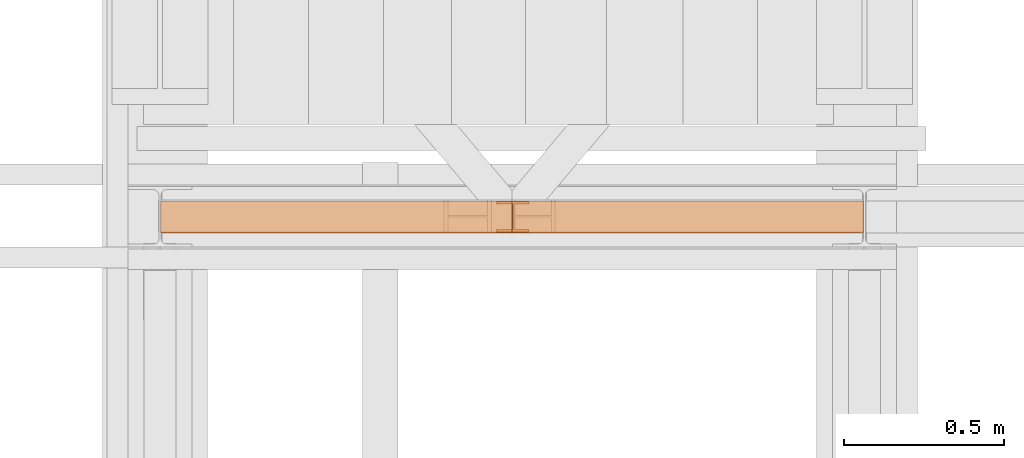
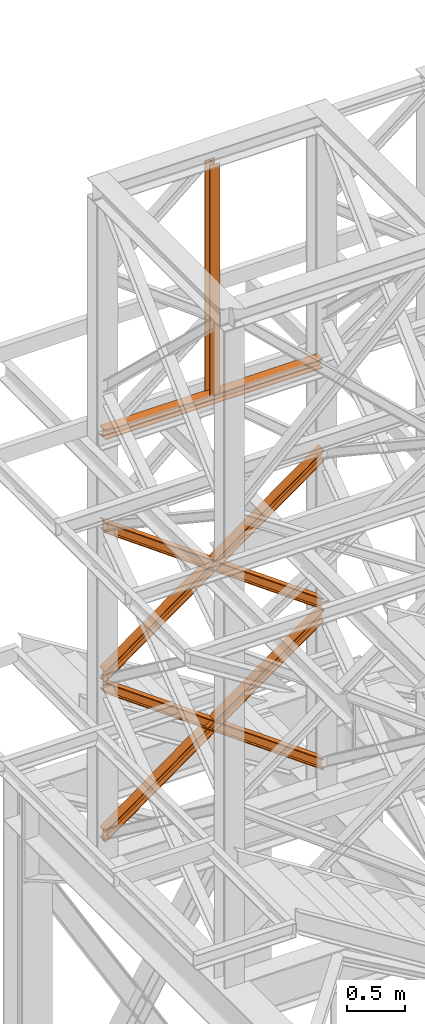
# One storey, part 102 of 208: 6 proxies.
"""IFC2X3 building model written with IfcOpenShell, lengths in millimetres."""

from ifc_helpers import new_model, entity, si_unit, converted_unit, frame, origin, origin_with_axes, place, context, subcontext, project, spatial, faceted_brep, element, save


model = new_model("IFC2X3")

# Units and contexts
model_context = context("Model", 3, precision=1e-05, world=origin())
plan_context = context("Plan", 3, precision=1e-05, world=origin())
body_context = subcontext(model_context, "Body", "Model", "MODEL_VIEW")
ifc_project = project(units=[si_unit("LENGTHUNIT", "METRE", prefix="MILLI"), converted_unit("PLANEANGLEUNIT", "DEGREE", entity("IfcPlaneAngleMeasure", 0.0174532925199433), si_unit("PLANEANGLEUNIT", "RADIAN"), dimensions=[0, 0, 0, 0, 0, 0, 0]), si_unit("AREAUNIT", "SQUARE_METRE"), si_unit("VOLUMEUNIT", "CUBIC_METRE")], contexts=[model_context, plan_context])

# Building, storey
building_placement = place(None, origin())
building = spatial("IfcBuilding", under=ifc_project, at=building_placement, CompositionType="COMPLEX")
storey_placement = place(building_placement, origin_with_axes())
storey = spatial("IfcBuildingStorey", under=building, at=storey_placement, Name="Geschoss", CompositionType="ELEMENT")

# Proxies
proxy_1_placement = place(storey_placement, frame((-3304.245031471322, -13812.57439031789, 5434.990005364416), z_axis=(0.0, 0.0, 1.0), x_axis=(1.0, 0.0, 0.0)))
element("IfcBuildingElementProxy", 1, at=proxy_1_placement, inside=storey, context=body_context, shape_type="Brep", body=[
    faceted_brep([(2194.25999993293, 0.01000000000021828, 1583.81921929576), (0.01000000000021828, 0.01000000000021828, 0.01000000000112777), (0.01000000000021828, 0.01000000000021828, 9.69256505868816), (2194.25999993293, 0.01000000000021828, 1593.501784354445), (2194.25999993293, 100.0100000000002, 1583.819219295759), (0.01000000000021828, 100.0100000000002, 0.01000000000021828), (0.01000000000021828, 0.01000000000021828, 0.01000000000112777), (2194.25999993293, 0.01000000000021828, 1583.81921929576), (2194.25999993293, 100.0100000000002, 1593.501784354445), (0.01000000000021828, 100.0100000000002, 9.69256505868816), (0.01000000000021828, 100.0100000000002, 0.01000000000021828), (2194.25999993293, 100.0100000000002, 1583.819219295759), (2194.25999993293, 52.51000000000022, 1593.501784354445), (0.01000000000021828, 52.51000000000022, 9.69256505868816), (0.01000000000021828, 100.0100000000002, 9.69256505868816), (2194.25999993293, 100.0100000000002, 1593.501784354445), (2194.259999932929, 52.51000000000022, 1690.327434941312), (0.01000000000021828, 52.51000000000022, 106.5182156455558), (0.01000000000021828, 52.51000000000022, 9.69256505868816), (2194.25999993293, 52.51000000000022, 1593.501784354445), (2194.25999993293, 100.0100000000002, 1690.327434941312), (0.01000000000203727, 100.0100000000002, 106.5182156455558), (0.01000000000021828, 52.51000000000022, 106.5182156455558), (2194.259999932929, 52.51000000000022, 1690.327434941312), (2194.25999993293, 100.0100000000002, 1700.01), (0.01000000000021828, 100.0100000000002, 116.2007807042428), (0.01000000000203727, 100.0100000000002, 106.5182156455558), (2194.25999993293, 100.0100000000002, 1690.327434941312), (2194.259999932929, 0.01000000000021828, 1700.01), (0.01000000000021828, 0.01000000000021828, 116.2007807042428), (0.01000000000021828, 100.0100000000002, 116.2007807042428), (2194.25999993293, 100.0100000000002, 1700.01), (2194.25999993293, 0.01000000000021828, 1690.327434941312), (0.01000000000021828, 0.01000000000021828, 106.5182156455549), (0.01000000000021828, 0.01000000000021828, 116.2007807042428), (2194.259999932929, 0.01000000000021828, 1700.01), (2194.25999993293, 47.51000000000022, 1690.327434941311), (0.01000000000021828, 47.51000000000022, 106.5182156455549), (0.01000000000021828, 0.01000000000021828, 106.5182156455549), (2194.25999993293, 0.01000000000021828, 1690.327434941312), (2194.25999993293, 47.51000000000022, 1593.501784354445), (0.01000000000021828, 47.51000000000022, 9.69256505868816), (0.01000000000021828, 47.51000000000022, 106.5182156455549), (2194.25999993293, 47.51000000000022, 1690.327434941311), (2194.25999993293, 0.01000000000021828, 1593.501784354445), (0.01000000000021828, 0.01000000000021828, 9.69256505868816), (0.01000000000021828, 47.51000000000022, 9.69256505868816), (2194.25999993293, 47.51000000000022, 1593.501784354445), (2194.25999993293, 0.01000000000021828, 1593.501784354445), (2194.25999993293, 47.51000000000022, 1593.501784354445), (2194.25999993293, 47.51000000000022, 1690.327434941311), (2194.25999993293, 0.01000000000021828, 1690.327434941312), (2194.259999932929, 0.01000000000021828, 1700.01), (2194.25999993293, 100.0100000000002, 1700.01), (2194.25999993293, 100.0100000000002, 1690.327434941312), (2194.259999932929, 52.51000000000022, 1690.327434941312), (2194.25999993293, 52.51000000000022, 1593.501784354445), (2194.25999993293, 100.0100000000002, 1593.501784354445), (2194.25999993293, 100.0100000000002, 1583.819219295759), (2194.25999993293, 0.01000000000021828, 1583.81921929576), (0.01000000000021828, 0.01000000000021828, 0.01000000000112777), (0.01000000000021828, 100.0100000000002, 0.01000000000021828), (0.01000000000021828, 100.0100000000002, 9.69256505868816), (0.01000000000021828, 52.51000000000022, 9.69256505868816), (0.01000000000021828, 52.51000000000022, 106.5182156455558), (0.01000000000203727, 100.0100000000002, 106.5182156455558), (0.01000000000021828, 100.0100000000002, 116.2007807042428), (0.01000000000021828, 0.01000000000021828, 116.2007807042428), (0.01000000000021828, 0.01000000000021828, 106.5182156455549), (0.01000000000021828, 47.51000000000022, 106.5182156455549), (0.01000000000021828, 47.51000000000022, 9.69256505868816), (0.01000000000021828, 0.01000000000021828, 9.69256505868816)], [[[0, 1, 2, 3]], [[4, 5, 6, 7]], [[8, 9, 10, 11]], [[12, 13, 14, 15]], [[16, 17, 18, 19]], [[20, 21, 22, 23]], [[24, 25, 26, 27]], [[28, 29, 30, 31]], [[32, 33, 34, 35]], [[36, 37, 38, 39]], [[40, 41, 42, 43]], [[44, 45, 46, 47]], [[48, 49, 50, 51, 52, 53, 54, 55, 56, 57, 58, 59]], [[60, 61, 62, 63, 64, 65, 66, 67, 68, 69, 70, 71]]], orient=[[False], [False], [False], [False], [False], [False], [False], [False], [False], [False], [False], [False], [False], [False]]),
])
proxy_2_placement = place(storey_placement, frame((-3304.245031471322, -13812.57439031789, 5434.990005364416), z_axis=(0.0, 0.0, 1.0), x_axis=(1.0, 0.0, 0.0)))
element("IfcBuildingElementProxy", 2, at=proxy_2_placement, inside=storey, context=body_context, shape_type="Brep", body=[
    faceted_brep([(0.01000000000021828, 0.01000000000021828, 1593.501784354445), (2194.25999993293, 0.01000000000021828, 9.692565058686341), (2194.25999993293, 0.01000000000021828, 0.01000000000112777), (0.01000000000021828, 0.01000000000021828, 1583.819219295759), (0.01000000000021828, 0.01000000000021828, 1583.819219295759), (2194.25999993293, 0.01000000000021828, 0.01000000000112777), (2194.25999993293, 100.0100000000002, 0.01000000000021828), (0.01000000000021828, 100.0100000000002, 1583.819219295759), (0.01000000000021828, 100.0100000000002, 1583.819219295759), (2194.25999993293, 100.0100000000002, 0.01000000000021828), (2194.25999993293, 100.0100000000002, 9.692565058686341), (0.01000000000021828, 100.0100000000002, 1593.501784354445), (0.01000000000021828, 100.0100000000002, 1593.501784354445), (2194.25999993293, 100.0100000000002, 9.692565058686341), (2194.25999993293, 52.51000000000022, 9.692565058686341), (0.01000000000021828, 52.51000000000022, 1593.501784354445), (0.01000000000021828, 52.51000000000022, 1593.501784354445), (2194.25999993293, 52.51000000000022, 9.692565058686341), (2194.259999932929, 52.51000000000022, 106.5182156455549), (0.01000000000021828, 52.51000000000022, 1690.327434941313), (0.01000000000021828, 52.51000000000022, 1690.327434941313), (2194.259999932929, 52.51000000000022, 106.5182156455549), (2194.25999993293, 100.0100000000002, 106.5182156455549), (0.01000000000021828, 100.0100000000002, 1690.327434941311), (0.01000000000021828, 100.0100000000002, 1690.327434941311), (2194.25999993293, 100.0100000000002, 106.5182156455549), (2194.259999932929, 100.0100000000002, 116.2007807042419), (0.01000000000021828, 100.0100000000002, 1700.01), (0.01000000000021828, 100.0100000000002, 1700.01), (2194.259999932929, 100.0100000000002, 116.2007807042419), (2194.25999993293, 0.01000000000021828, 116.2007807042419), (0.01000000000021828, 0.01000000000021828, 1700.01), (0.01000000000021828, 0.01000000000021828, 1700.01), (2194.25999993293, 0.01000000000021828, 116.2007807042419), (2194.25999993293, 0.01000000000021828, 106.5182156455549), (0.01000000000021828, 0.01000000000021828, 1690.327434941313), (0.01000000000021828, 0.01000000000021828, 1690.327434941313), (2194.25999993293, 0.01000000000021828, 106.5182156455549), (2194.25999993293, 47.51000000000022, 106.5182156455539), (0.01000000000021828, 47.51000000000022, 1690.327434941311), (0.01000000000021828, 47.51000000000022, 1690.327434941311), (2194.25999993293, 47.51000000000022, 106.5182156455539), (2194.25999993293, 47.51000000000022, 9.692565058686341), (0.01000000000021828, 47.51000000000022, 1593.501784354445), (0.01000000000021828, 47.51000000000022, 1593.501784354445), (2194.25999993293, 47.51000000000022, 9.692565058686341), (2194.25999993293, 0.01000000000021828, 9.692565058686341), (0.01000000000021828, 0.01000000000021828, 1593.501784354445), (2194.25999993293, 0.01000000000021828, 9.692565058686341), (2194.25999993293, 47.51000000000022, 9.692565058686341), (2194.25999993293, 47.51000000000022, 106.5182156455539), (2194.25999993293, 0.01000000000021828, 106.5182156455549), (2194.25999993293, 0.01000000000021828, 116.2007807042419), (2194.259999932929, 100.0100000000002, 116.2007807042419), (2194.25999993293, 100.0100000000002, 106.5182156455549), (2194.259999932929, 52.51000000000022, 106.5182156455549), (2194.25999993293, 52.51000000000022, 9.692565058686341), (2194.25999993293, 100.0100000000002, 9.692565058686341), (2194.25999993293, 100.0100000000002, 0.01000000000021828), (2194.25999993293, 0.01000000000021828, 0.01000000000112777), (0.01000000000021828, 0.01000000000021828, 1583.819219295759), (0.01000000000021828, 100.0100000000002, 1583.819219295759), (0.01000000000021828, 100.0100000000002, 1593.501784354445), (0.01000000000021828, 52.51000000000022, 1593.501784354445), (0.01000000000021828, 52.51000000000022, 1690.327434941313), (0.01000000000021828, 100.0100000000002, 1690.327434941311), (0.01000000000021828, 100.0100000000002, 1700.01), (0.01000000000021828, 0.01000000000021828, 1700.01), (0.01000000000021828, 0.01000000000021828, 1690.327434941313), (0.01000000000021828, 47.51000000000022, 1690.327434941311), (0.01000000000021828, 47.51000000000022, 1593.501784354445), (0.01000000000021828, 0.01000000000021828, 1593.501784354445)], [[[0, 1, 2, 3]], [[4, 5, 6, 7]], [[8, 9, 10, 11]], [[12, 13, 14, 15]], [[16, 17, 18, 19]], [[20, 21, 22, 23]], [[24, 25, 26, 27]], [[28, 29, 30, 31]], [[32, 33, 34, 35]], [[36, 37, 38, 39]], [[40, 41, 42, 43]], [[44, 45, 46, 47]], [[48, 49, 50, 51, 52, 53, 54, 55, 56, 57, 58, 59]], [[60, 61, 62, 63, 64, 65, 66, 67, 68, 69, 70, 71]]], orient=[[False], [False], [False], [False], [False], [False], [False], [False], [False], [False], [False], [False], [False], [False]]),
])
proxy_3_placement = place(storey_placement, frame((-3304.245031471322, -13812.57439031789, 7134.990005364416), z_axis=(0.0, 0.0, 1.0), x_axis=(1.0, 0.0, 0.0)))
element("IfcBuildingElementProxy", 3, at=proxy_3_placement, inside=storey, context=body_context, shape_type="Brep", body=[
    faceted_brep([(2194.25999993293, 0.01000000000021828, 1583.81921929576), (0.01000000000021828, 0.01000000000021828, 0.01000000000112777), (0.01000000000021828, 0.01000000000021828, 9.69256505868816), (2194.25999993293, 0.01000000000021828, 1593.501784354445), (2194.25999993293, 100.0100000000002, 1583.819219295758), (0.01000000000021828, 100.0100000000002, 0.01000000000021828), (0.01000000000021828, 0.01000000000021828, 0.01000000000112777), (2194.25999993293, 0.01000000000021828, 1583.81921929576), (2194.25999993293, 100.0100000000002, 1593.501784354445), (0.01000000000021828, 100.0100000000002, 9.69256505868816), (0.01000000000021828, 100.0100000000002, 0.01000000000021828), (2194.25999993293, 100.0100000000002, 1583.819219295758), (2194.25999993293, 52.51000000000022, 1593.501784354445), (0.01000000000021828, 52.51000000000022, 9.69256505868816), (0.01000000000021828, 100.0100000000002, 9.69256505868816), (2194.25999993293, 100.0100000000002, 1593.501784354445), (2194.259999932929, 52.51000000000022, 1690.327434941311), (0.01000000000021828, 52.51000000000022, 106.5182156455558), (0.01000000000021828, 52.51000000000022, 9.69256505868816), (2194.25999993293, 52.51000000000022, 1593.501784354445), (2194.25999993293, 100.0100000000002, 1690.327434941311), (0.01000000000203727, 100.0100000000002, 106.5182156455558), (0.01000000000021828, 52.51000000000022, 106.5182156455558), (2194.259999932929, 52.51000000000022, 1690.327434941311), (2194.25999993293, 100.0100000000002, 1700.01), (0.01000000000021828, 100.0100000000002, 116.2007807042428), (0.01000000000203727, 100.0100000000002, 106.5182156455558), (2194.25999993293, 100.0100000000002, 1690.327434941311), (2194.259999932929, 0.01000000000021828, 1700.01), (0.01000000000021828, 0.01000000000021828, 116.2007807042428), (0.01000000000021828, 100.0100000000002, 116.2007807042428), (2194.25999993293, 100.0100000000002, 1700.01), (2194.25999993293, 0.01000000000021828, 1690.327434941311), (0.01000000000021828, 0.01000000000021828, 106.5182156455549), (0.01000000000021828, 0.01000000000021828, 116.2007807042428), (2194.259999932929, 0.01000000000021828, 1700.01), (2194.25999993293, 47.51000000000022, 1690.327434941311), (0.01000000000021828, 47.51000000000022, 106.5182156455549), (0.01000000000021828, 0.01000000000021828, 106.5182156455549), (2194.25999993293, 0.01000000000021828, 1690.327434941311), (2194.25999993293, 47.51000000000022, 1593.501784354445), (0.01000000000021828, 47.51000000000022, 9.69256505868816), (0.01000000000021828, 47.51000000000022, 106.5182156455549), (2194.25999993293, 47.51000000000022, 1690.327434941311), (2194.25999993293, 0.01000000000021828, 1593.501784354445), (0.01000000000021828, 0.01000000000021828, 9.69256505868816), (0.01000000000021828, 47.51000000000022, 9.69256505868816), (2194.25999993293, 47.51000000000022, 1593.501784354445), (2194.25999993293, 0.01000000000021828, 1593.501784354445), (2194.25999993293, 47.51000000000022, 1593.501784354445), (2194.25999993293, 47.51000000000022, 1690.327434941311), (2194.25999993293, 0.01000000000021828, 1690.327434941311), (2194.259999932929, 0.01000000000021828, 1700.01), (2194.25999993293, 100.0100000000002, 1700.01), (2194.25999993293, 100.0100000000002, 1690.327434941311), (2194.259999932929, 52.51000000000022, 1690.327434941311), (2194.25999993293, 52.51000000000022, 1593.501784354445), (2194.25999993293, 100.0100000000002, 1593.501784354445), (2194.25999993293, 100.0100000000002, 1583.819219295758), (2194.25999993293, 0.01000000000021828, 1583.81921929576), (0.01000000000021828, 0.01000000000021828, 0.01000000000112777), (0.01000000000021828, 100.0100000000002, 0.01000000000021828), (0.01000000000021828, 100.0100000000002, 9.69256505868816), (0.01000000000021828, 52.51000000000022, 9.69256505868816), (0.01000000000021828, 52.51000000000022, 106.5182156455558), (0.01000000000203727, 100.0100000000002, 106.5182156455558), (0.01000000000021828, 100.0100000000002, 116.2007807042428), (0.01000000000021828, 0.01000000000021828, 116.2007807042428), (0.01000000000021828, 0.01000000000021828, 106.5182156455549), (0.01000000000021828, 47.51000000000022, 106.5182156455549), (0.01000000000021828, 47.51000000000022, 9.69256505868816), (0.01000000000021828, 0.01000000000021828, 9.69256505868816)], [[[0, 1, 2, 3]], [[4, 5, 6, 7]], [[8, 9, 10, 11]], [[12, 13, 14, 15]], [[16, 17, 18, 19]], [[20, 21, 22, 23]], [[24, 25, 26, 27]], [[28, 29, 30, 31]], [[32, 33, 34, 35]], [[36, 37, 38, 39]], [[40, 41, 42, 43]], [[44, 45, 46, 47]], [[48, 49, 50, 51, 52, 53, 54, 55, 56, 57, 58, 59]], [[60, 61, 62, 63, 64, 65, 66, 67, 68, 69, 70, 71]]], orient=[[False], [False], [False], [False], [False], [False], [False], [False], [False], [False], [False], [False], [False], [False]]),
])
proxy_4_placement = place(storey_placement, frame((-3304.245031471322, -13812.57439031789, 7134.990005364416), z_axis=(0.0, 0.0, 1.0), x_axis=(1.0, 0.0, 0.0)))
element("IfcBuildingElementProxy", 4, at=proxy_4_placement, inside=storey, context=body_context, shape_type="Brep", body=[
    faceted_brep([(0.01000000000021828, 0.01000000000021828, 1593.501784354445), (2194.25999993293, 0.01000000000021828, 9.692565058686341), (2194.25999993293, 0.01000000000021828, 0.01000000000112777), (0.01000000000021828, 0.01000000000021828, 1583.819219295758), (0.01000000000021828, 0.01000000000021828, 1583.819219295758), (2194.25999993293, 0.01000000000021828, 0.01000000000112777), (2194.25999993293, 100.0100000000002, 0.01000000000021828), (0.01000000000021828, 100.0100000000002, 1583.819219295758), (0.01000000000021828, 100.0100000000002, 1583.819219295758), (2194.25999993293, 100.0100000000002, 0.01000000000021828), (2194.25999993293, 100.0100000000002, 9.692565058686341), (0.01000000000021828, 100.0100000000002, 1593.501784354445), (0.01000000000021828, 100.0100000000002, 1593.501784354445), (2194.25999993293, 100.0100000000002, 9.692565058686341), (2194.25999993293, 52.51000000000022, 9.692565058686341), (0.01000000000021828, 52.51000000000022, 1593.501784354445), (0.01000000000021828, 52.51000000000022, 1593.501784354445), (2194.25999993293, 52.51000000000022, 9.692565058686341), (2194.259999932929, 52.51000000000022, 106.5182156455549), (0.01000000000021828, 52.51000000000022, 1690.327434941313), (0.01000000000021828, 52.51000000000022, 1690.327434941313), (2194.259999932929, 52.51000000000022, 106.5182156455549), (2194.25999993293, 100.0100000000002, 106.5182156455549), (0.01000000000021828, 100.0100000000002, 1690.327434941311), (0.01000000000021828, 100.0100000000002, 1690.327434941311), (2194.25999993293, 100.0100000000002, 106.5182156455549), (2194.259999932929, 100.0100000000002, 116.2007807042419), (0.01000000000021828, 100.0100000000002, 1700.01), (0.01000000000021828, 100.0100000000002, 1700.01), (2194.259999932929, 100.0100000000002, 116.2007807042419), (2194.25999993293, 0.01000000000021828, 116.2007807042419), (0.01000000000021828, 0.01000000000021828, 1700.01), (0.01000000000021828, 0.01000000000021828, 1700.01), (2194.25999993293, 0.01000000000021828, 116.2007807042419), (2194.25999993293, 0.01000000000021828, 106.5182156455549), (0.01000000000021828, 0.01000000000021828, 1690.327434941313), (0.01000000000021828, 0.01000000000021828, 1690.327434941313), (2194.25999993293, 0.01000000000021828, 106.5182156455549), (2194.25999993293, 47.51000000000022, 106.5182156455539), (0.01000000000021828, 47.51000000000022, 1690.327434941311), (0.01000000000021828, 47.51000000000022, 1690.327434941311), (2194.25999993293, 47.51000000000022, 106.5182156455539), (2194.25999993293, 47.51000000000022, 9.692565058686341), (0.01000000000021828, 47.51000000000022, 1593.501784354445), (0.01000000000021828, 47.51000000000022, 1593.501784354445), (2194.25999993293, 47.51000000000022, 9.692565058686341), (2194.25999993293, 0.01000000000021828, 9.692565058686341), (0.01000000000021828, 0.01000000000021828, 1593.501784354445), (2194.25999993293, 0.01000000000021828, 9.692565058686341), (2194.25999993293, 47.51000000000022, 9.692565058686341), (2194.25999993293, 47.51000000000022, 106.5182156455539), (2194.25999993293, 0.01000000000021828, 106.5182156455549), (2194.25999993293, 0.01000000000021828, 116.2007807042419), (2194.259999932929, 100.0100000000002, 116.2007807042419), (2194.25999993293, 100.0100000000002, 106.5182156455549), (2194.259999932929, 52.51000000000022, 106.5182156455549), (2194.25999993293, 52.51000000000022, 9.692565058686341), (2194.25999993293, 100.0100000000002, 9.692565058686341), (2194.25999993293, 100.0100000000002, 0.01000000000021828), (2194.25999993293, 0.01000000000021828, 0.01000000000112777), (0.01000000000021828, 0.01000000000021828, 1583.819219295758), (0.01000000000021828, 100.0100000000002, 1583.819219295758), (0.01000000000021828, 100.0100000000002, 1593.501784354445), (0.01000000000021828, 52.51000000000022, 1593.501784354445), (0.01000000000021828, 52.51000000000022, 1690.327434941313), (0.01000000000021828, 100.0100000000002, 1690.327434941311), (0.01000000000021828, 100.0100000000002, 1700.01), (0.01000000000021828, 0.01000000000021828, 1700.01), (0.01000000000021828, 0.01000000000021828, 1690.327434941313), (0.01000000000021828, 47.51000000000022, 1690.327434941311), (0.01000000000021828, 47.51000000000022, 1593.501784354445), (0.01000000000021828, 0.01000000000021828, 1593.501784354445)], [[[0, 1, 2, 3]], [[4, 5, 6, 7]], [[8, 9, 10, 11]], [[12, 13, 14, 15]], [[16, 17, 18, 19]], [[20, 21, 22, 23]], [[24, 25, 26, 27]], [[28, 29, 30, 31]], [[32, 33, 34, 35]], [[36, 37, 38, 39]], [[40, 41, 42, 43]], [[44, 45, 46, 47]], [[48, 49, 50, 51, 52, 53, 54, 55, 56, 57, 58, 59]], [[60, 61, 62, 63, 64, 65, 66, 67, 68, 69, 70, 71]]], orient=[[False], [False], [False], [False], [False], [False], [False], [False], [False], [False], [False], [False], [False], [False]]),
])
proxy_5_placement = place(storey_placement, frame((-2255.013511169444, -13810.57439404318, 9798.084114618363), z_axis=(0.0, 0.0, 1.0), x_axis=(1.0, 0.0, 0.0)))
element("IfcBuildingElementProxy", 5, at=proxy_5_placement, inside=storey, context=body_context, shape_type="Brep", body=[
    faceted_brep([(0.01000000000021828, 88.01000000000022, 0.05126551053399453), (47.50999595574831, 88.01000000000022, 0.03166439303095103), (47.50999595574831, 8.010000000000218, 0.03166439303095103), (0.01000000000021828, 8.010000000000218, 0.05126551053399453), (0.01000000000021828, 0.01000000000021828, 0.05126551053399453), (100.0099914857874, 0.01000000000021828, 0.01000000000021828), (100.0099914857874, 8.010000000000218, 0.01000000000021828), (52.50999553003749, 8.010000000000218, 0.02960111750326178), (52.50999553003749, 88.01000000000022, 0.02960111750326178), (100.0099914857874, 88.01000000000022, 0.01000000000021828), (100.0099914857874, 96.01000000000022, 0.01000000000021828), (0.01000000000021828, 96.01000000000022, 0.05126551053399453), (0.01000000000021828, 96.01000000000022, 0.05126551053399453), (1.021782592853924, 96.01000000000022, 2451.935402223362), (1.021782592853924, 88.01000000000022, 2451.935402223362), (0.01000000000021828, 88.01000000000022, 0.05126551053399453), (100.0099914857874, 96.01000000000022, 0.01000000000021828), (101.0217740786411, 96.01000000000022, 2451.894136712828), (1.021782592853924, 96.01000000000022, 2451.935402223362), (0.01000000000021828, 96.01000000000022, 0.05126551053399453), (100.0099914857874, 88.01000000000022, 0.01000000000021828), (101.0217740786411, 88.01000000000022, 2451.894136712828), (101.0217740786411, 96.01000000000022, 2451.894136712828), (100.0099914857874, 96.01000000000022, 0.01000000000021828), (52.50999553003749, 88.01000000000022, 0.02960111750326178), (53.52177812289119, 88.01000000000022, 2451.913737830331), (101.0217740786411, 88.01000000000022, 2451.894136712828), (100.0099914857874, 88.01000000000022, 0.01000000000021828), (52.50999553003749, 8.010000000000218, 0.02960111750326178), (53.52177812289119, 8.010000000000218, 2451.913737830331), (53.52177812289119, 88.01000000000022, 2451.913737830331), (52.50999553003749, 88.01000000000022, 0.02960111750326178), (100.0099914857874, 8.010000000000218, 0.01000000000021828), (101.0217740786411, 8.010000000000218, 2451.894136712828), (53.52177812289119, 8.010000000000218, 2451.913737830331), (52.50999553003749, 8.010000000000218, 0.02960111750326178), (100.0099914857874, 0.01000000000021828, 0.01000000000021828), (101.0217740786411, 0.01000000000021828, 2451.894136712828), (101.0217740786411, 8.010000000000218, 2451.894136712828), (100.0099914857874, 8.010000000000218, 0.01000000000021828), (0.01000000000021828, 0.01000000000021828, 0.05126551053399453), (1.021782592853924, 0.01000000000021828, 2451.935402223362), (101.0217740786411, 0.01000000000021828, 2451.894136712828), (100.0099914857874, 0.01000000000021828, 0.01000000000021828), (0.01000000000021828, 8.010000000000218, 0.05126551053399453), (1.021782592853924, 8.010000000000218, 2451.935402223362), (1.021782592853924, 0.01000000000021828, 2451.935402223362), (0.01000000000021828, 0.01000000000021828, 0.05126551053399453), (47.50999595574831, 8.010000000000218, 0.03166439303095103), (48.52177854860202, 8.010000000000218, 2451.915801105857), (1.021782592853924, 8.010000000000218, 2451.935402223362), (0.01000000000021828, 8.010000000000218, 0.05126551053399453), (47.50999595574831, 88.01000000000022, 0.03166439303095103), (48.52177854860202, 88.01000000000022, 2451.915801105857), (48.52177854860202, 8.010000000000218, 2451.915801105857), (47.50999595574831, 8.010000000000218, 0.03166439303095103), (0.01000000000021828, 88.01000000000022, 0.05126551053399453), (1.021782592853924, 88.01000000000022, 2451.935402223362), (48.52177854860202, 88.01000000000022, 2451.915801105857), (47.50999595574831, 88.01000000000022, 0.03166439303095103), (1.021782592853924, 88.01000000000022, 2451.935402223362), (1.021782592853924, 96.01000000000022, 2451.935402223362), (101.0217740786411, 96.01000000000022, 2451.894136712828), (101.0217740786411, 88.01000000000022, 2451.894136712828), (53.52177812289119, 88.01000000000022, 2451.913737830331), (53.52177812289119, 8.010000000000218, 2451.913737830331), (101.0217740786411, 8.010000000000218, 2451.894136712828), (101.0217740786411, 0.01000000000021828, 2451.894136712828), (1.021782592853924, 0.01000000000021828, 2451.935402223362), (1.021782592853924, 8.010000000000218, 2451.935402223362), (48.52177854860202, 8.010000000000218, 2451.915801105857), (48.52177854860202, 88.01000000000022, 2451.915801105857)], [[[0, 1, 2, 3, 4, 5, 6, 7, 8, 9, 10, 11]], [[12, 13, 14, 15]], [[16, 17, 18, 19]], [[20, 21, 22, 23]], [[24, 25, 26, 27]], [[28, 29, 30, 31]], [[32, 33, 34, 35]], [[36, 37, 38, 39]], [[40, 41, 42, 43]], [[44, 45, 46, 47]], [[48, 49, 50, 51]], [[52, 53, 54, 55]], [[56, 57, 58, 59]], [[60, 61, 62, 63, 64, 65, 66, 67, 68, 69, 70, 71]]], orient=[[False], [False], [False], [False], [False], [False], [False], [False], [False], [False], [False], [False], [False], [False]]),
])
proxy_6_placement = place(storey_placement, frame((-3304.74936182461, -13812.57439031789, 9709.656976133134), z_axis=(0.0, 0.0, 1.0), x_axis=(1.0, 0.0, 0.0)))
element("IfcBuildingElementProxy", 6, at=proxy_6_placement, inside=storey, context=body_context, shape_type="Brep", body=[
    faceted_brep([(0.0133012408423383, 0.01000000000021828, 8.91157471702536), (0.01000000000021828, 0.01000000000021828, 0.9115753981623129), (0.01000000000021828, 100.0100000000002, 0.9115753981623129), (0.0133012408423383, 100.0100000000002, 8.91157471702536), (0.0133012408423383, 52.51000000000022, 8.91157471702536), (0.04631364926899551, 52.51000000000022, 88.91156790565765), (0.04631364926899551, 100.0100000000002, 88.91156790565765), (0.04961489011293452, 100.0100000000002, 96.91156722451888), (0.04961489011293452, 0.01000000000021828, 96.91156722451888), (0.04631364926899551, 0.01000000000021828, 88.91156790565765), (0.04631364926899551, 47.51000000000022, 88.91156790565765), (0.0133012408423383, 47.51000000000022, 8.91157471702536), (0.01000000000021828, 0.01000000000021828, 0.9115753981623129), (0.0133012408423383, 0.01000000000021828, 8.91157471702536), (2184.828925096716, 0.01000000000385626, 8.009999318863265), (2184.825623855873, 0.01000000000385626, 0.01000000000203727), (0.01000000000021828, 100.0100000000002, 0.9115753981623129), (0.01000000000021828, 0.01000000000021828, 0.9115753981623129), (2184.825623855873, 0.01000000000385626, 0.01000000000203727), (2184.825623855873, 100.0100000000039, 0.01000000000021828), (0.0133012408423383, 100.0100000000002, 8.91157471702536), (0.01000000000021828, 100.0100000000002, 0.9115753981623129), (2184.825623855873, 100.0100000000039, 0.01000000000021828), (2184.828925096716, 100.0100000000039, 8.009999318863265), (0.0133012408423383, 52.51000000000022, 8.91157471702536), (0.0133012408423383, 100.0100000000002, 8.91157471702536), (2184.828925096716, 100.0100000000039, 8.009999318863265), (2184.828925096716, 52.51000000000386, 8.009999318863265), (0.04631364926899551, 52.51000000000022, 88.91156790565765), (0.0133012408423383, 52.51000000000022, 8.91157471702536), (2184.828925096716, 52.51000000000386, 8.009999318863265), (2184.861937505142, 52.51000000000386, 88.00999250749555), (0.04631364926899551, 100.0100000000002, 88.91156790565765), (0.04631364926899551, 52.51000000000022, 88.91156790565765), (2184.861937505142, 52.51000000000386, 88.00999250749555), (2184.861937505142, 100.0100000000039, 88.00999250749555), (0.04961489011293452, 100.0100000000002, 96.91156722451888), (0.04631364926899551, 100.0100000000002, 88.91156790565765), (2184.861937505142, 100.0100000000039, 88.00999250749555), (2184.865238745986, 100.0100000000039, 96.00999182635678), (0.04961489011293452, 0.01000000000021828, 96.91156722451888), (0.04961489011293452, 100.0100000000002, 96.91156722451888), (2184.865238745986, 100.0100000000039, 96.00999182635678), (2184.865238745986, 0.01000000000385626, 96.00999182635678), (0.04631364926899551, 0.01000000000021828, 88.91156790565765), (0.04961489011293452, 0.01000000000021828, 96.91156722451888), (2184.865238745986, 0.01000000000385626, 96.00999182635678), (2184.861937505142, 0.01000000000385626, 88.00999250749373), (0.04631364926899551, 47.51000000000022, 88.91156790565765), (0.04631364926899551, 0.01000000000021828, 88.91156790565765), (2184.861937505142, 0.01000000000385626, 88.00999250749373), (2184.861937505142, 47.51000000000386, 88.00999250749555), (0.0133012408423383, 47.51000000000022, 8.91157471702536), (0.04631364926899551, 47.51000000000022, 88.91156790565765), (2184.861937505142, 47.51000000000386, 88.00999250749555), (2184.828925096716, 47.51000000000386, 8.009999318863265), (0.0133012408423383, 0.01000000000021828, 8.91157471702536), (0.0133012408423383, 47.51000000000022, 8.91157471702536), (2184.828925096716, 47.51000000000386, 8.009999318863265), (2184.828925096716, 0.01000000000385626, 8.009999318863265), (2184.828925096716, 0.01000000000385626, 8.009999318863265), (2184.828925096716, 47.51000000000386, 8.009999318863265), (2184.861937505142, 47.51000000000386, 88.00999250749555), (2184.861937505142, 0.01000000000385626, 88.00999250749373), (2184.865238745986, 0.01000000000385626, 96.00999182635678), (2184.865238745986, 100.0100000000039, 96.00999182635678), (2184.861937505142, 100.0100000000039, 88.00999250749555), (2184.861937505142, 52.51000000000386, 88.00999250749555), (2184.828925096716, 52.51000000000386, 8.009999318863265), (2184.828925096716, 100.0100000000039, 8.009999318863265), (2184.825623855873, 100.0100000000039, 0.01000000000021828), (2184.825623855873, 0.01000000000385626, 0.01000000000203727)], [[[0, 1, 2, 3, 4, 5, 6, 7, 8, 9, 10, 11]], [[12, 13, 14, 15]], [[16, 17, 18, 19]], [[20, 21, 22, 23]], [[24, 25, 26, 27]], [[28, 29, 30, 31]], [[32, 33, 34, 35]], [[36, 37, 38, 39]], [[40, 41, 42, 43]], [[44, 45, 46, 47]], [[48, 49, 50, 51]], [[52, 53, 54, 55]], [[56, 57, 58, 59]], [[60, 61, 62, 63, 64, 65, 66, 67, 68, 69, 70, 71]]], orient=[[False], [False], [False], [False], [False], [False], [False], [False], [False], [False], [False], [False], [False], [False]]),
])

save(model, "model.ifc")
